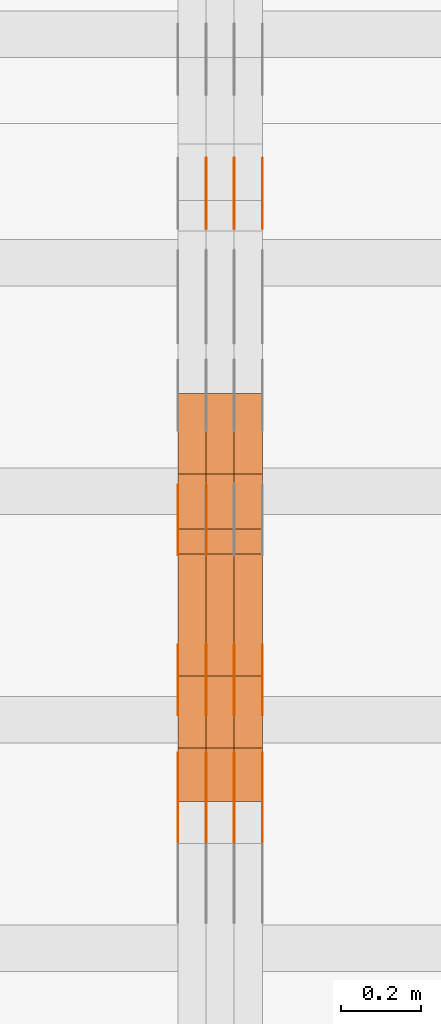
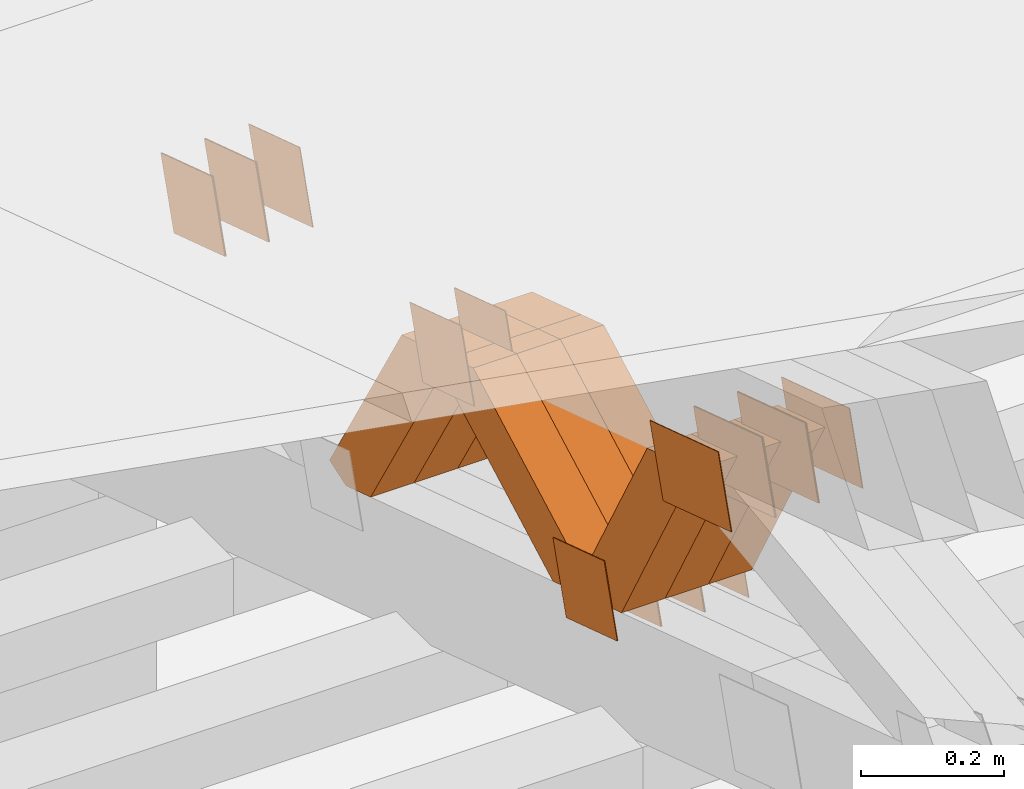
# One storey, part 190 of 385: 28 proxies.
"""IFC2X3 building model written with IfcOpenShell, lengths in millimetres."""

from ifc_helpers import new_model, entity, si_unit, converted_unit, derived_unit, direction, frame, origin, place, context, subcontext, project, spatial, polyline, outline, extrude, source, transform, mapped, material, type_object, type_shapes, element, save


model = new_model("IFC2X3")

# Units and contexts
model_context = context("Model", 3, precision=0.01, world=origin(), true_north=direction((6.12303176911189e-17, 1.0)))
body_context = subcontext(model_context, "Body", "Model", "MODEL_VIEW")
ifc_project = project(units=[si_unit("LENGTHUNIT", "METRE", prefix="MILLI"), si_unit("AREAUNIT", "SQUARE_METRE"), si_unit("VOLUMEUNIT", "CUBIC_METRE"), converted_unit("PLANEANGLEUNIT", "DEGREE", entity("IfcRatioMeasure", 0.0174532925199433), si_unit("PLANEANGLEUNIT", "RADIAN"), dimensions=[0, 0, 0, 0, 0, 0, 0]), si_unit("MASSUNIT", "GRAM", prefix="KILO"), derived_unit("MASSDENSITYUNIT", [(si_unit("MASSUNIT", "GRAM", prefix="KILO"), 1), (si_unit("LENGTHUNIT", "METRE"), -3)]), si_unit("TIMEUNIT", "SECOND"), si_unit("FREQUENCYUNIT", "HERTZ"), si_unit("THERMODYNAMICTEMPERATUREUNIT", "DEGREE_CELSIUS"), derived_unit("THERMALTRANSMITTANCEUNIT", [(si_unit("MASSUNIT", "GRAM", prefix="KILO"), 1), (si_unit("THERMODYNAMICTEMPERATUREUNIT", "KELVIN"), -1), (si_unit("TIMEUNIT", "SECOND"), -3)]), derived_unit("VOLUMETRICFLOWRATEUNIT", [(si_unit("LENGTHUNIT", "METRE"), 3), (si_unit("TIMEUNIT", "SECOND"), -1)]), si_unit("ELECTRICCURRENTUNIT", "AMPERE"), si_unit("ELECTRICVOLTAGEUNIT", "VOLT"), si_unit("POWERUNIT", "WATT"), si_unit("FORCEUNIT", "NEWTON", prefix="KILO"), si_unit("ILLUMINANCEUNIT", "LUX"), si_unit("LUMINOUSFLUXUNIT", "LUMEN"), si_unit("LUMINOUSINTENSITYUNIT", "CANDELA"), derived_unit("USERDEFINED", [(si_unit("MASSUNIT", "GRAM", prefix="KILO"), -1), (si_unit("LENGTHUNIT", "METRE"), -2), (si_unit("TIMEUNIT", "SECOND"), 3), (si_unit("LUMINOUSFLUXUNIT", "LUMEN"), 1)]), derived_unit("LINEARVELOCITYUNIT", [(si_unit("LENGTHUNIT", "METRE"), 1), (si_unit("TIMEUNIT", "SECOND"), -1)]), si_unit("PRESSUREUNIT", "PASCAL"), derived_unit("USERDEFINED", [(si_unit("LENGTHUNIT", "METRE"), -2), (si_unit("MASSUNIT", "GRAM", prefix="KILO"), 1), (si_unit("TIMEUNIT", "SECOND"), -2)])], contexts=[model_context])

# Site, building, storey
site_placement = place(None, origin())
site = spatial("IfcSite", under=ifc_project, at=site_placement, CompositionType="ELEMENT")
building_placement = place(site_placement, origin())
building = spatial("IfcBuilding", under=site, at=building_placement, CompositionType="ELEMENT")
storey_placement = place(building_placement, origin())
storey = spatial("IfcBuildingStorey", under=building, at=storey_placement, Name="Default", CompositionType="ELEMENT", Elevation=0.0)

# Proxies
ifc_material_1 = material(Name="IfcSurfaceStyle #143354")
building_element_proxy_type_1 = type_object("IfcBuildingElementProxyType", PredefinedType="NOTDEFINED", material=ifc_material_1)
shared_shape_1 = source(origin(), body_context, "Body", "SweptSolid", [
    extrude(outline(polyline([(-74.9998605591059, -59.9999264677526), (74.999875428623, -59.9999264677526), (74.9998605591068, 59.9999264677526), (-74.9998754286239, 59.9999264677526), (-74.9998605591059, -59.9999264677526)])), frame((75.0000889884782, 60.0000460315623, 0.0), z_axis=(0.0, 0.0, 1.0), x_axis=(-1.0, 0.0, 0.0)), (0.0, 0.0, 1.0), 1.3),
])
type_shapes(building_element_proxy_type_1, [shared_shape_1])
proxy_1_placement = place(building_placement, frame((9386.29999999998, 20621.9679769682, 2241.76551219004), z_axis=(-1.0, 0.0, 0.0), x_axis=(0.0, -0.951056516295154, 0.309016994374948)))
element("IfcBuildingElementProxy", 1, at=proxy_1_placement, inside=storey, type_object=building_element_proxy_type_1, material=ifc_material_1, context=body_context, shape_type="MappedRepresentation", body=[
    mapped(shared_shape_1, transform((0.0, 0.0, 0.0), scale=1.0)),
])
ifc_material_2 = material(Name="IfcSurfaceStyle #143297")
building_element_proxy_type_2 = type_object("IfcBuildingElementProxyType", PredefinedType="NOTDEFINED", material=ifc_material_2)
shared_shape_2 = source(origin(), body_context, "Body", "SweptSolid", [
    extrude(outline(polyline([(-74.9998605591059, -59.9999264677526), (74.999875428623, -59.9999264677526), (74.9998605591068, 59.9999264677526), (-74.9998754286239, 59.9999264677526), (-74.9998605591059, -59.9999264677526)])), frame((75.0000889884782, 60.0000460315623, 0.0), z_axis=(0.0, 0.0, 1.0), x_axis=(-1.0, 0.0, 0.0)), (0.0, 0.0, 1.0), 1.3),
])
type_shapes(building_element_proxy_type_2, [shared_shape_2])
proxy_2_placement = place(building_placement, frame((9315.0, 20621.9679769682, 2241.76551219004), z_axis=(-1.0, 0.0, 0.0), x_axis=(0.0, -0.951056516295154, 0.309016994374948)))
element("IfcBuildingElementProxy", 2, at=proxy_2_placement, inside=storey, type_object=building_element_proxy_type_2, material=ifc_material_2, context=body_context, shape_type="MappedRepresentation", body=[
    mapped(shared_shape_2, transform((0.0, 0.0, 0.0), scale=1.0)),
])
ifc_material_3 = material(Name="IfcSurfaceStyle #143240")
building_element_proxy_type_3 = type_object("IfcBuildingElementProxyType", PredefinedType="NOTDEFINED", material=ifc_material_3)
shared_shape_3 = source(origin(), body_context, "Body", "SweptSolid", [
    extrude(outline(polyline([(-74.9998605591059, -59.9999264677526), (74.999875428623, -59.9999264677526), (74.9998605591068, 59.9999264677526), (-74.9998754286239, 59.9999264677526), (-74.9998605591059, -59.9999264677526)])), frame((75.0000889884782, 60.0000460315623, 0.0), z_axis=(0.0, 0.0, 1.0), x_axis=(-1.0, 0.0, 0.0)), (0.0, 0.0, 1.0), 1.3),
])
type_shapes(building_element_proxy_type_3, [shared_shape_3])
proxy_3_placement = place(building_placement, frame((9316.29999999998, 20621.9679769682, 2241.76551219004), z_axis=(-1.0, 0.0, 0.0), x_axis=(0.0, -0.951056516295154, 0.309016994374948)))
element("IfcBuildingElementProxy", 3, at=proxy_3_placement, inside=storey, type_object=building_element_proxy_type_3, material=ifc_material_3, context=body_context, shape_type="MappedRepresentation", body=[
    mapped(shared_shape_3, transform((0.0, 0.0, 0.0), scale=1.0)),
])
ifc_material_4 = material(Name="IfcSurfaceStyle #143183")
building_element_proxy_type_4 = type_object("IfcBuildingElementProxyType", PredefinedType="NOTDEFINED", material=ifc_material_4)
shared_shape_4 = source(origin(), body_context, "Body", "SweptSolid", [
    extrude(outline(polyline([(-74.9998605591059, -59.9999264677526), (74.999875428623, -59.9999264677526), (74.9998605591068, 59.9999264677526), (-74.9998754286239, 59.9999264677526), (-74.9998605591059, -59.9999264677526)])), frame((75.0000889884782, 60.0000460315623, 0.0), z_axis=(0.0, 0.0, 1.0), x_axis=(-1.0, 0.0, 0.0)), (0.0, 0.0, 1.0), 1.29999999999999),
])
type_shapes(building_element_proxy_type_4, [shared_shape_4])
proxy_4_placement = place(building_placement, frame((9245.0, 20621.9679769682, 2241.76551219004), z_axis=(-1.0, 0.0, 0.0), x_axis=(0.0, -0.951056516295154, 0.309016994374948)))
element("IfcBuildingElementProxy", 4, at=proxy_4_placement, inside=storey, type_object=building_element_proxy_type_4, material=ifc_material_4, context=body_context, shape_type="MappedRepresentation", body=[
    mapped(shared_shape_4, transform((0.0, 0.0, 0.0), scale=1.0)),
])
ifc_material_5 = material(Name="IfcSurfaceStyle #143126")
building_element_proxy_type_5 = type_object("IfcBuildingElementProxyType", PredefinedType="NOTDEFINED", material=ifc_material_5)
shared_shape_5 = source(origin(), body_context, "Body", "SweptSolid", [
    extrude(outline(polyline([(-74.9998605591059, -59.9999264677526), (74.999875428623, -59.9999264677526), (74.9998605591068, 59.9999264677526), (-74.9998754286239, 59.9999264677526), (-74.9998605591059, -59.9999264677526)])), frame((75.0000889884782, 60.0000460315623, 0.0), z_axis=(0.0, 0.0, 1.0), x_axis=(-1.0, 0.0, 0.0)), (0.0, 0.0, 1.0), 1.29999999999999),
])
type_shapes(building_element_proxy_type_5, [shared_shape_5])
proxy_5_placement = place(building_placement, frame((9246.29999999998, 20621.9679769682, 2241.76551219004), z_axis=(-1.0, 0.0, 0.0), x_axis=(0.0, -0.951056516295154, 0.309016994374948)))
element("IfcBuildingElementProxy", 5, at=proxy_5_placement, inside=storey, type_object=building_element_proxy_type_5, material=ifc_material_5, context=body_context, shape_type="MappedRepresentation", body=[
    mapped(shared_shape_5, transform((0.0, 0.0, 0.0), scale=1.0)),
])
ifc_material_6 = material(Name="IfcSurfaceStyle #141758")
building_element_proxy_type_6 = type_object("IfcBuildingElementProxyType", PredefinedType="NOTDEFINED", material=ifc_material_6)
shared_shape_6 = source(origin(), body_context, "Body", "SweptSolid", [
    extrude(outline(polyline([(-74.9998982809088, -60.000042563519), (74.9998377068237, -60.000042563519), (74.9998982809079, 60.0000425635189), (-74.9998377068227, 60.0000425635189), (-74.9998982809088, -60.000042563519)])), frame((75.0001050385304, 60.0001177331169, 0.0), z_axis=(0.0, 0.0, 1.0), x_axis=(-1.0, 0.0, 0.0)), (0.0, 0.0, 1.0), 1.29999999999999),
])
type_shapes(building_element_proxy_type_6, [shared_shape_6])
proxy_6_placement = place(building_placement, frame((9246.29999999998, 19806.7306653882, 2506.65203571776), z_axis=(-1.0, 0.0, 0.0), x_axis=(0.0, -0.951056516295154, 0.309016994374948)))
element("IfcBuildingElementProxy", 6, at=proxy_6_placement, inside=storey, type_object=building_element_proxy_type_6, material=ifc_material_6, context=body_context, shape_type="MappedRepresentation", body=[
    mapped(shared_shape_6, transform((0.0, 0.0, 0.0), scale=1.0)),
])
ifc_material_7 = material(Name="IfcSurfaceStyle #141701")
building_element_proxy_type_7 = type_object("IfcBuildingElementProxyType", PredefinedType="NOTDEFINED", material=ifc_material_7)
shared_shape_7 = source(origin(), body_context, "Body", "SweptSolid", [
    extrude(outline(polyline([(-74.9998982809088, -60.000042563519), (74.9998377068237, -60.000042563519), (74.9998982809079, 60.0000425635189), (-74.9998377068227, 60.0000425635189), (-74.9998982809088, -60.000042563519)])), frame((75.0001050385304, 60.0001177331169, 0.0), z_axis=(0.0, 0.0, 1.0), x_axis=(-1.0, 0.0, 0.0)), (0.0, 0.0, 1.0), 1.29999999999999),
])
type_shapes(building_element_proxy_type_7, [shared_shape_7])
proxy_7_placement = place(building_placement, frame((9175.0, 19806.7306653882, 2506.65203571776), z_axis=(-1.0, 0.0, 0.0), x_axis=(0.0, -0.951056516295154, 0.309016994374948)))
element("IfcBuildingElementProxy", 7, at=proxy_7_placement, inside=storey, type_object=building_element_proxy_type_7, material=ifc_material_7, context=body_context, shape_type="MappedRepresentation", body=[
    mapped(shared_shape_7, transform((0.0, 0.0, 0.0), scale=1.0)),
])
ifc_material_8 = material(Name="IfcSurfaceStyle #140618")
building_element_proxy_type_8 = type_object("IfcBuildingElementProxyType", PredefinedType="NOTDEFINED", material=ifc_material_8)
shared_shape_8 = source(origin(), body_context, "Body", "SweptSolid", [
    extrude(outline(polyline([(-99.9998479918963, -59.9999913366637), (99.9998251396114, -59.9999913366637), (99.9998102700952, 59.9999913366637), (-99.9997874178102, 59.9999913366637), (-99.9998479918963, -59.9999913366637)])), frame((99.9998251396114, 60.0000609537942, 0.0), z_axis=(0.0, 0.0, 1.0), x_axis=(-1.0, 0.0, 0.0)), (0.0, 0.0, 1.0), 1.3),
])
type_shapes(building_element_proxy_type_8, [shared_shape_8])
proxy_8_placement = place(building_placement, frame((9386.29999999998, 19136.9072023289, 2711.67346128215), z_axis=(-1.0, 0.0, 0.0), x_axis=(0.0, -0.951056516295154, 0.309016994374948)))
element("IfcBuildingElementProxy", 8, at=proxy_8_placement, inside=storey, type_object=building_element_proxy_type_8, material=ifc_material_8, context=body_context, shape_type="MappedRepresentation", body=[
    mapped(shared_shape_8, transform((0.0, 0.0, 0.0), scale=1.0)),
])
ifc_material_9 = material(Name="IfcSurfaceStyle #140561")
building_element_proxy_type_9 = type_object("IfcBuildingElementProxyType", PredefinedType="NOTDEFINED", material=ifc_material_9)
shared_shape_9 = source(origin(), body_context, "Body", "SweptSolid", [
    extrude(outline(polyline([(-99.9998479918963, -59.9999913366637), (99.9998251396114, -59.9999913366637), (99.9998102700952, 59.9999913366637), (-99.9997874178102, 59.9999913366637), (-99.9998479918963, -59.9999913366637)])), frame((99.9998251396114, 60.0000609537942, 0.0), z_axis=(0.0, 0.0, 1.0), x_axis=(-1.0, 0.0, 0.0)), (0.0, 0.0, 1.0), 1.3),
])
type_shapes(building_element_proxy_type_9, [shared_shape_9])
proxy_9_placement = place(building_placement, frame((9315.0, 19136.9072023289, 2711.67346128215), z_axis=(-1.0, 0.0, 0.0), x_axis=(0.0, -0.951056516295154, 0.309016994374948)))
element("IfcBuildingElementProxy", 9, at=proxy_9_placement, inside=storey, type_object=building_element_proxy_type_9, material=ifc_material_9, context=body_context, shape_type="MappedRepresentation", body=[
    mapped(shared_shape_9, transform((0.0, 0.0, 0.0), scale=1.0)),
])
ifc_material_10 = material(Name="IfcSurfaceStyle #140504")
building_element_proxy_type_10 = type_object("IfcBuildingElementProxyType", PredefinedType="NOTDEFINED", material=ifc_material_10)
shared_shape_10 = source(origin(), body_context, "Body", "SweptSolid", [
    extrude(outline(polyline([(-99.9998479918963, -59.9999913366637), (99.9998251396114, -59.9999913366637), (99.9998102700952, 59.9999913366637), (-99.9997874178102, 59.9999913366637), (-99.9998479918963, -59.9999913366637)])), frame((99.9998251396114, 60.0000609537942, 0.0), z_axis=(0.0, 0.0, 1.0), x_axis=(-1.0, 0.0, 0.0)), (0.0, 0.0, 1.0), 1.3),
])
type_shapes(building_element_proxy_type_10, [shared_shape_10])
proxy_10_placement = place(building_placement, frame((9316.29999999998, 19136.9072023289, 2711.67346128215), z_axis=(-1.0, 0.0, 0.0), x_axis=(0.0, -0.951056516295154, 0.309016994374948)))
element("IfcBuildingElementProxy", 10, at=proxy_10_placement, inside=storey, type_object=building_element_proxy_type_10, material=ifc_material_10, context=body_context, shape_type="MappedRepresentation", body=[
    mapped(shared_shape_10, transform((0.0, 0.0, 0.0), scale=1.0)),
])
ifc_material_11 = material(Name="IfcSurfaceStyle #140447")
building_element_proxy_type_11 = type_object("IfcBuildingElementProxyType", PredefinedType="NOTDEFINED", material=ifc_material_11)
shared_shape_11 = source(origin(), body_context, "Body", "SweptSolid", [
    extrude(outline(polyline([(-99.9998479918963, -59.9999913366637), (99.9998251396114, -59.9999913366637), (99.9998102700952, 59.9999913366637), (-99.9997874178102, 59.9999913366637), (-99.9998479918963, -59.9999913366637)])), frame((99.9998251396114, 60.0000609537942, 0.0), z_axis=(0.0, 0.0, 1.0), x_axis=(-1.0, 0.0, 0.0)), (0.0, 0.0, 1.0), 1.29999999999998),
])
type_shapes(building_element_proxy_type_11, [shared_shape_11])
proxy_11_placement = place(building_placement, frame((9245.0, 19136.9072023289, 2711.67346128215), z_axis=(-1.0, 0.0, 0.0), x_axis=(0.0, -0.951056516295154, 0.309016994374948)))
element("IfcBuildingElementProxy", 11, at=proxy_11_placement, inside=storey, type_object=building_element_proxy_type_11, material=ifc_material_11, context=body_context, shape_type="MappedRepresentation", body=[
    mapped(shared_shape_11, transform((0.0, 0.0, 0.0), scale=1.0)),
])
ifc_material_12 = material(Name="IfcSurfaceStyle #140390")
building_element_proxy_type_12 = type_object("IfcBuildingElementProxyType", PredefinedType="NOTDEFINED", material=ifc_material_12)
shared_shape_12 = source(origin(), body_context, "Body", "SweptSolid", [
    extrude(outline(polyline([(-99.9998479918963, -59.9999913366637), (99.9998251396114, -59.9999913366637), (99.9998102700952, 59.9999913366637), (-99.9997874178102, 59.9999913366637), (-99.9998479918963, -59.9999913366637)])), frame((99.9998251396114, 60.0000609537942, 0.0), z_axis=(0.0, 0.0, 1.0), x_axis=(-1.0, 0.0, 0.0)), (0.0, 0.0, 1.0), 1.29999999999998),
])
type_shapes(building_element_proxy_type_12, [shared_shape_12])
proxy_12_placement = place(building_placement, frame((9246.29999999998, 19136.9072023289, 2711.67346128215), z_axis=(-1.0, 0.0, 0.0), x_axis=(0.0, -0.951056516295154, 0.309016994374948)))
element("IfcBuildingElementProxy", 12, at=proxy_12_placement, inside=storey, type_object=building_element_proxy_type_12, material=ifc_material_12, context=body_context, shape_type="MappedRepresentation", body=[
    mapped(shared_shape_12, transform((0.0, 0.0, 0.0), scale=1.0)),
])
ifc_material_13 = material(Name="IfcSurfaceStyle #140333")
building_element_proxy_type_13 = type_object("IfcBuildingElementProxyType", PredefinedType="NOTDEFINED", material=ifc_material_13)
shared_shape_13 = source(origin(), body_context, "Body", "SweptSolid", [
    extrude(outline(polyline([(-99.9998479918963, -59.9999913366637), (99.9998251396114, -59.9999913366637), (99.9998102700952, 59.9999913366637), (-99.9997874178102, 59.9999913366637), (-99.9998479918963, -59.9999913366637)])), frame((99.9998251396114, 60.0000609537942, 0.0), z_axis=(0.0, 0.0, 1.0), x_axis=(-1.0, 0.0, 0.0)), (0.0, 0.0, 1.0), 1.29999999999999),
])
type_shapes(building_element_proxy_type_13, [shared_shape_13])
proxy_13_placement = place(building_placement, frame((9175.0, 19136.9072023289, 2711.67346128215), z_axis=(-1.0, 0.0, 0.0), x_axis=(0.0, -0.951056516295154, 0.309016994374948)))
element("IfcBuildingElementProxy", 13, at=proxy_13_placement, inside=storey, type_object=building_element_proxy_type_13, material=ifc_material_13, context=body_context, shape_type="MappedRepresentation", body=[
    mapped(shared_shape_13, transform((0.0, 0.0, 0.0), scale=1.0)),
])
ifc_material_14 = material(Name="IfcSurfaceStyle #135488")
building_element_proxy_type_14 = type_object("IfcBuildingElementProxyType", PredefinedType="NOTDEFINED", material=ifc_material_14)
shared_shape_14 = source(origin(), body_context, "Body", "SweptSolid", [
    extrude(outline(polyline([(-74.9998605591127, -59.9999264677599), (74.999875428618, -59.9999264677599), (74.9998605591127, 59.9999264677599), (-74.999875428618, 59.9999264677599), (-74.9998605591127, -59.9999264677599)])), frame((75.0002655673825, 60.0000016373433, 0.0), z_axis=(0.0, 0.0, 1.0), x_axis=(-1.0, 0.0, 0.0)), (0.0, 0.0, 1.0), 1.3),
])
type_shapes(building_element_proxy_type_14, [shared_shape_14])
proxy_14_placement = place(building_placement, frame((9386.29999999998, 19407.1136664358, 2348.71056820494), z_axis=(-1.0, 0.0, 0.0), x_axis=(0.0, -0.951056516295124, 0.309016994375039)))
element("IfcBuildingElementProxy", 14, at=proxy_14_placement, inside=storey, type_object=building_element_proxy_type_14, material=ifc_material_14, context=body_context, shape_type="MappedRepresentation", body=[
    mapped(shared_shape_14, transform((0.0, 0.0, 0.0), scale=1.0)),
])
ifc_material_15 = material(Name="IfcSurfaceStyle #135431")
building_element_proxy_type_15 = type_object("IfcBuildingElementProxyType", PredefinedType="NOTDEFINED", material=ifc_material_15)
shared_shape_15 = source(origin(), body_context, "Body", "SweptSolid", [
    extrude(outline(polyline([(-74.9998605591127, -59.9999264677599), (74.999875428618, -59.9999264677599), (74.9998605591127, 59.9999264677599), (-74.999875428618, 59.9999264677599), (-74.9998605591127, -59.9999264677599)])), frame((75.0002655673825, 60.0000016373433, 0.0), z_axis=(0.0, 0.0, 1.0), x_axis=(-1.0, 0.0, 0.0)), (0.0, 0.0, 1.0), 1.3),
])
type_shapes(building_element_proxy_type_15, [shared_shape_15])
proxy_15_placement = place(building_placement, frame((9315.0, 19407.1136664358, 2348.71056820494), z_axis=(-1.0, 0.0, 0.0), x_axis=(0.0, -0.951056516295124, 0.309016994375039)))
element("IfcBuildingElementProxy", 15, at=proxy_15_placement, inside=storey, type_object=building_element_proxy_type_15, material=ifc_material_15, context=body_context, shape_type="MappedRepresentation", body=[
    mapped(shared_shape_15, transform((0.0, 0.0, 0.0), scale=1.0)),
])
ifc_material_16 = material(Name="IfcSurfaceStyle #135374")
building_element_proxy_type_16 = type_object("IfcBuildingElementProxyType", PredefinedType="NOTDEFINED", material=ifc_material_16)
shared_shape_16 = source(origin(), body_context, "Body", "SweptSolid", [
    extrude(outline(polyline([(-74.9998605591127, -59.9999264677599), (74.999875428618, -59.9999264677599), (74.9998605591127, 59.9999264677599), (-74.999875428618, 59.9999264677599), (-74.9998605591127, -59.9999264677599)])), frame((75.0002655673825, 60.0000016373433, 0.0), z_axis=(0.0, 0.0, 1.0), x_axis=(-1.0, 0.0, 0.0)), (0.0, 0.0, 1.0), 1.3),
])
type_shapes(building_element_proxy_type_16, [shared_shape_16])
proxy_16_placement = place(building_placement, frame((9316.29999999998, 19407.1136664358, 2348.71056820494), z_axis=(-1.0, 0.0, 0.0), x_axis=(0.0, -0.951056516295124, 0.309016994375039)))
element("IfcBuildingElementProxy", 16, at=proxy_16_placement, inside=storey, type_object=building_element_proxy_type_16, material=ifc_material_16, context=body_context, shape_type="MappedRepresentation", body=[
    mapped(shared_shape_16, transform((0.0, 0.0, 0.0), scale=1.0)),
])
ifc_material_17 = material(Name="IfcSurfaceStyle #135317")
building_element_proxy_type_17 = type_object("IfcBuildingElementProxyType", PredefinedType="NOTDEFINED", material=ifc_material_17)
shared_shape_17 = source(origin(), body_context, "Body", "SweptSolid", [
    extrude(outline(polyline([(-74.9998605591127, -59.9999264677599), (74.999875428618, -59.9999264677599), (74.9998605591127, 59.9999264677599), (-74.999875428618, 59.9999264677599), (-74.9998605591127, -59.9999264677599)])), frame((75.0002655673825, 60.0000016373433, 0.0), z_axis=(0.0, 0.0, 1.0), x_axis=(-1.0, 0.0, 0.0)), (0.0, 0.0, 1.0), 1.29999999999999),
])
type_shapes(building_element_proxy_type_17, [shared_shape_17])
proxy_17_placement = place(building_placement, frame((9245.0, 19407.1136664358, 2348.71056820494), z_axis=(-1.0, 0.0, 0.0), x_axis=(0.0, -0.951056516295124, 0.309016994375039)))
element("IfcBuildingElementProxy", 17, at=proxy_17_placement, inside=storey, type_object=building_element_proxy_type_17, material=ifc_material_17, context=body_context, shape_type="MappedRepresentation", body=[
    mapped(shared_shape_17, transform((0.0, 0.0, 0.0), scale=1.0)),
])
ifc_material_18 = material(Name="IfcSurfaceStyle #135260")
building_element_proxy_type_18 = type_object("IfcBuildingElementProxyType", PredefinedType="NOTDEFINED", material=ifc_material_18)
shared_shape_18 = source(origin(), body_context, "Body", "SweptSolid", [
    extrude(outline(polyline([(-74.9998605591127, -59.9999264677599), (74.999875428618, -59.9999264677599), (74.9998605591127, 59.9999264677599), (-74.999875428618, 59.9999264677599), (-74.9998605591127, -59.9999264677599)])), frame((75.0002655673825, 60.0000016373433, 0.0), z_axis=(0.0, 0.0, 1.0), x_axis=(-1.0, 0.0, 0.0)), (0.0, 0.0, 1.0), 1.29999999999999),
])
type_shapes(building_element_proxy_type_18, [shared_shape_18])
proxy_18_placement = place(building_placement, frame((9246.29999999998, 19407.1136664358, 2348.71056820494), z_axis=(-1.0, 0.0, 0.0), x_axis=(0.0, -0.951056516295124, 0.309016994375039)))
element("IfcBuildingElementProxy", 18, at=proxy_18_placement, inside=storey, type_object=building_element_proxy_type_18, material=ifc_material_18, context=body_context, shape_type="MappedRepresentation", body=[
    mapped(shared_shape_18, transform((0.0, 0.0, 0.0), scale=1.0)),
])
ifc_material_19 = material(Name="IfcSurfaceStyle #135203")
building_element_proxy_type_19 = type_object("IfcBuildingElementProxyType", PredefinedType="NOTDEFINED", material=ifc_material_19)
shared_shape_19 = source(origin(), body_context, "Body", "SweptSolid", [
    extrude(outline(polyline([(-74.9998605591127, -59.9999264677599), (74.999875428618, -59.9999264677599), (74.9998605591127, 59.9999264677599), (-74.999875428618, 59.9999264677599), (-74.9998605591127, -59.9999264677599)])), frame((75.0002655673825, 60.0000016373433, 0.0), z_axis=(0.0, 0.0, 1.0), x_axis=(-1.0, 0.0, 0.0)), (0.0, 0.0, 1.0), 1.29999999999999),
])
type_shapes(building_element_proxy_type_19, [shared_shape_19])
proxy_19_placement = place(building_placement, frame((9175.0, 19407.1136664358, 2348.71056820494), z_axis=(-1.0, 0.0, 0.0), x_axis=(0.0, -0.951056516295124, 0.309016994375039)))
element("IfcBuildingElementProxy", 19, at=proxy_19_placement, inside=storey, type_object=building_element_proxy_type_19, material=ifc_material_19, context=body_context, shape_type="MappedRepresentation", body=[
    mapped(shared_shape_19, transform((0.0, 0.0, 0.0), scale=1.0)),
])
ifc_material_20 = material(Name="IfcSurfaceStyle #118730")
building_element_proxy_type_20 = type_object("IfcBuildingElementProxyType", Name="T1-W40 118728", PredefinedType="NOTDEFINED", material=ifc_material_20)
shared_shape_20 = source(origin(), body_context, "Body", "SweptSolid", [
    extrude(outline(polyline([(-190.697067347251, -47.4992767218045), (178.704677543904, -47.4992767218045), (178.119540532346, -0.000296092407564622), (126.935785980356, 47.4999913795318), (-293.062936709355, 47.4988581564849), (-190.697067347251, -47.4992767218045)])), frame((178.7049897723, 47.4999913795318, 0.0), z_axis=(0.0, 0.0, 1.0), x_axis=(-1.0, 0.0, 0.0)), (0.0, 0.0, 1.0), 70.0),
])
type_shapes(building_element_proxy_type_20, [shared_shape_20])
proxy_20_placement = place(building_placement, frame((9385.0, 19280.269490882, 2403.36730959494), z_axis=(-1.0, 0.0, 0.0), x_axis=(0.0, -0.48691092455798, 0.873451630913866)))
element("IfcBuildingElementProxy", 20, at=proxy_20_placement, inside=storey, type_object=building_element_proxy_type_20, material=ifc_material_20, Name="T1-W40", context=body_context, shape_type="MappedRepresentation", body=[
    mapped(shared_shape_20, transform((0.0, 0.0, 0.0), scale=1.0)),
])
ifc_material_21 = material(Name="IfcSurfaceStyle #118664")
building_element_proxy_type_21 = type_object("IfcBuildingElementProxyType", Name="T1-W40 118662", PredefinedType="NOTDEFINED", material=ifc_material_21)
shared_shape_21 = source(origin(), body_context, "Body", "SweptSolid", [
    extrude(outline(polyline([(-190.697067347251, -47.4992767218045), (178.704677543904, -47.4992767218045), (178.119540532346, -0.000296092407564622), (126.935785980356, 47.4999913795318), (-293.062936709355, 47.4988581564849), (-190.697067347251, -47.4992767218045)])), frame((178.7049897723, 47.4999913795318, 0.0), z_axis=(0.0, 0.0, 1.0), x_axis=(-1.0, 0.0, 0.0)), (0.0, 0.0, 1.0), 70.0),
])
type_shapes(building_element_proxy_type_21, [shared_shape_21])
proxy_21_placement = place(building_placement, frame((9315.0, 19280.269490882, 2403.36730959494), z_axis=(-1.0, 0.0, 0.0), x_axis=(0.0, -0.48691092455798, 0.873451630913866)))
element("IfcBuildingElementProxy", 21, at=proxy_21_placement, inside=storey, type_object=building_element_proxy_type_21, material=ifc_material_21, Name="T1-W40", context=body_context, shape_type="MappedRepresentation", body=[
    mapped(shared_shape_21, transform((0.0, 0.0, 0.0), scale=1.0)),
])
ifc_material_22 = material(Name="IfcSurfaceStyle #118598")
building_element_proxy_type_22 = type_object("IfcBuildingElementProxyType", Name="T1-W40 118596", PredefinedType="NOTDEFINED", material=ifc_material_22)
shared_shape_22 = source(origin(), body_context, "Body", "SweptSolid", [
    extrude(outline(polyline([(-190.697067347251, -47.4992767218045), (178.704677543904, -47.4992767218045), (178.119540532346, -0.000296092407564622), (126.935785980356, 47.4999913795318), (-293.062936709355, 47.4988581564849), (-190.697067347251, -47.4992767218045)])), frame((178.7049897723, 47.4999913795318, 0.0), z_axis=(0.0, 0.0, 1.0), x_axis=(-1.0, 0.0, 0.0)), (0.0, 0.0, 1.0), 70.0),
])
type_shapes(building_element_proxy_type_22, [shared_shape_22])
proxy_22_placement = place(building_placement, frame((9245.0, 19280.269490882, 2403.36730959494), z_axis=(-1.0, 0.0, 0.0), x_axis=(0.0, -0.48691092455798, 0.873451630913866)))
element("IfcBuildingElementProxy", 22, at=proxy_22_placement, inside=storey, type_object=building_element_proxy_type_22, material=ifc_material_22, Name="T1-W40", context=body_context, shape_type="MappedRepresentation", body=[
    mapped(shared_shape_22, transform((0.0, 0.0, 0.0), scale=1.0)),
])
ifc_material_23 = material(Name="IfcSurfaceStyle #118334")
building_element_proxy_type_23 = type_object("IfcBuildingElementProxyType", Name="T1-W47 118332", PredefinedType="NOTDEFINED", material=ifc_material_23)
shared_shape_23 = source(origin(), body_context, "Body", "SweptSolid", [
    extrude(outline(polyline([(-273.154581805017, -47.5000119135351), (121.157675769026, -47.5000119135351), (166.341960897813, -0.000128144957132403), (168.441931699108, 47.5000759860137), (-182.78698656093, 47.5000759860137), (-273.154581805017, -47.5000119135351)])), frame((168.441931699108, 47.5000759860137, 0.0), z_axis=(0.0, 0.0, 1.0), x_axis=(-1.0, 0.0, 0.0)), (0.0, 0.0, 1.0), 70.0),
])
type_shapes(building_element_proxy_type_23, [shared_shape_23])
proxy_23_placement = place(building_placement, frame((9385.0, 19755.0380859375, 2553.712890625), z_axis=(-1.0, 0.0, 0.0), x_axis=(0.0, -0.879386813332609, -0.476108005117242)))
element("IfcBuildingElementProxy", 23, at=proxy_23_placement, inside=storey, type_object=building_element_proxy_type_23, material=ifc_material_23, Name="T1-W47", context=body_context, shape_type="MappedRepresentation", body=[
    mapped(shared_shape_23, transform((0.0, 0.0, 0.0), scale=1.0)),
])
ifc_material_24 = material(Name="IfcSurfaceStyle #118268")
building_element_proxy_type_24 = type_object("IfcBuildingElementProxyType", Name="T1-W47 118266", PredefinedType="NOTDEFINED", material=ifc_material_24)
shared_shape_24 = source(origin(), body_context, "Body", "SweptSolid", [
    extrude(outline(polyline([(-273.154581805017, -47.5000119135351), (121.157675769026, -47.5000119135351), (166.341960897813, -0.000128144957132403), (168.441931699108, 47.5000759860137), (-182.78698656093, 47.5000759860137), (-273.154581805017, -47.5000119135351)])), frame((168.441931699108, 47.5000759860137, 0.0), z_axis=(0.0, 0.0, 1.0), x_axis=(-1.0, 0.0, 0.0)), (0.0, 0.0, 1.0), 70.0),
])
type_shapes(building_element_proxy_type_24, [shared_shape_24])
proxy_24_placement = place(building_placement, frame((9315.0, 19755.0380859375, 2553.712890625), z_axis=(-1.0, 0.0, 0.0), x_axis=(0.0, -0.879386813332609, -0.476108005117242)))
element("IfcBuildingElementProxy", 24, at=proxy_24_placement, inside=storey, type_object=building_element_proxy_type_24, material=ifc_material_24, Name="T1-W47", context=body_context, shape_type="MappedRepresentation", body=[
    mapped(shared_shape_24, transform((0.0, 0.0, 0.0), scale=1.0)),
])
ifc_material_25 = material(Name="IfcSurfaceStyle #118202")
building_element_proxy_type_25 = type_object("IfcBuildingElementProxyType", Name="T1-W47 118200", PredefinedType="NOTDEFINED", material=ifc_material_25)
shared_shape_25 = source(origin(), body_context, "Body", "SweptSolid", [
    extrude(outline(polyline([(-273.154581805017, -47.5000119135351), (121.157675769026, -47.5000119135351), (166.341960897813, -0.000128144957132403), (168.441931699108, 47.5000759860137), (-182.78698656093, 47.5000759860137), (-273.154581805017, -47.5000119135351)])), frame((168.441931699108, 47.5000759860137, 0.0), z_axis=(0.0, 0.0, 1.0), x_axis=(-1.0, 0.0, 0.0)), (0.0, 0.0, 1.0), 70.0),
])
type_shapes(building_element_proxy_type_25, [shared_shape_25])
proxy_25_placement = place(building_placement, frame((9245.0, 19755.0380859375, 2553.712890625), z_axis=(-1.0, 0.0, 0.0), x_axis=(0.0, -0.879386813332609, -0.476108005117242)))
element("IfcBuildingElementProxy", 25, at=proxy_25_placement, inside=storey, type_object=building_element_proxy_type_25, material=ifc_material_25, Name="T1-W47", context=body_context, shape_type="MappedRepresentation", body=[
    mapped(shared_shape_25, transform((0.0, 0.0, 0.0), scale=1.0)),
])
ifc_material_26 = material(Name="IfcSurfaceStyle #117938")
building_element_proxy_type_26 = type_object("IfcBuildingElementProxyType", Name="T1-W34 117936", PredefinedType="NOTDEFINED", material=ifc_material_26)
shared_shape_26 = source(origin(), body_context, "Body", "SweptSolid", [
    extrude(outline(polyline([(-197.657161937088, -47.499796538607), (193.17680883218, -47.499796538607), (182.92464491562, -1.98968224184526e-05), (128.354123102956, 47.4998064870182), (-306.798414913668, 47.4998064870182), (-197.657161937088, -47.499796538607)])), frame((193.176852028916, 47.4998566383869, 0.0), z_axis=(0.0, 0.0, 1.0), x_axis=(-1.0, 0.0, 0.0)), (0.0, 0.0, 1.0), 70.0),
])
type_shapes(building_element_proxy_type_26, [shared_shape_26])
proxy_26_placement = place(building_placement, frame((9385.0, 19987.8030409043, 2165.75390635484), z_axis=(-1.0, 0.0, 0.0), x_axis=(0.0, -0.514479403471631, 0.857502736674044)))
element("IfcBuildingElementProxy", 26, at=proxy_26_placement, inside=storey, type_object=building_element_proxy_type_26, material=ifc_material_26, Name="T1-W34", context=body_context, shape_type="MappedRepresentation", body=[
    mapped(shared_shape_26, transform((0.0, 0.0, 0.0), scale=1.0)),
])
ifc_material_27 = material(Name="IfcSurfaceStyle #117872")
building_element_proxy_type_27 = type_object("IfcBuildingElementProxyType", Name="T1-W34 117870", PredefinedType="NOTDEFINED", material=ifc_material_27)
shared_shape_27 = source(origin(), body_context, "Body", "SweptSolid", [
    extrude(outline(polyline([(-197.657161937088, -47.499796538607), (193.17680883218, -47.499796538607), (182.92464491562, -1.98968224184526e-05), (128.354123102956, 47.4998064870182), (-306.798414913668, 47.4998064870182), (-197.657161937088, -47.499796538607)])), frame((193.176852028916, 47.4998566383869, 0.0), z_axis=(0.0, 0.0, 1.0), x_axis=(-1.0, 0.0, 0.0)), (0.0, 0.0, 1.0), 70.0),
])
type_shapes(building_element_proxy_type_27, [shared_shape_27])
proxy_27_placement = place(building_placement, frame((9315.0, 19987.8030409043, 2165.75390635484), z_axis=(-1.0, 0.0, 0.0), x_axis=(0.0, -0.514479403471631, 0.857502736674044)))
element("IfcBuildingElementProxy", 27, at=proxy_27_placement, inside=storey, type_object=building_element_proxy_type_27, material=ifc_material_27, Name="T1-W34", context=body_context, shape_type="MappedRepresentation", body=[
    mapped(shared_shape_27, transform((0.0, 0.0, 0.0), scale=1.0)),
])
ifc_material_28 = material(Name="IfcSurfaceStyle #117806")
building_element_proxy_type_28 = type_object("IfcBuildingElementProxyType", Name="T1-W34 117804", PredefinedType="NOTDEFINED", material=ifc_material_28)
shared_shape_28 = source(origin(), body_context, "Body", "SweptSolid", [
    extrude(outline(polyline([(-197.657161937088, -47.499796538607), (193.17680883218, -47.499796538607), (182.92464491562, -1.98968224184526e-05), (128.354123102956, 47.4998064870182), (-306.798414913668, 47.4998064870182), (-197.657161937088, -47.499796538607)])), frame((193.176852028916, 47.4998566383869, 0.0), z_axis=(0.0, 0.0, 1.0), x_axis=(-1.0, 0.0, 0.0)), (0.0, 0.0, 1.0), 70.0),
])
type_shapes(building_element_proxy_type_28, [shared_shape_28])
proxy_28_placement = place(building_placement, frame((9245.0, 19987.8030409043, 2165.75390635484), z_axis=(-1.0, 0.0, 0.0), x_axis=(0.0, -0.514479403471631, 0.857502736674044)))
element("IfcBuildingElementProxy", 28, at=proxy_28_placement, inside=storey, type_object=building_element_proxy_type_28, material=ifc_material_28, Name="T1-W34", context=body_context, shape_type="MappedRepresentation", body=[
    mapped(shared_shape_28, transform((0.0, 0.0, 0.0), scale=1.0)),
])

save(model, "model.ifc")
